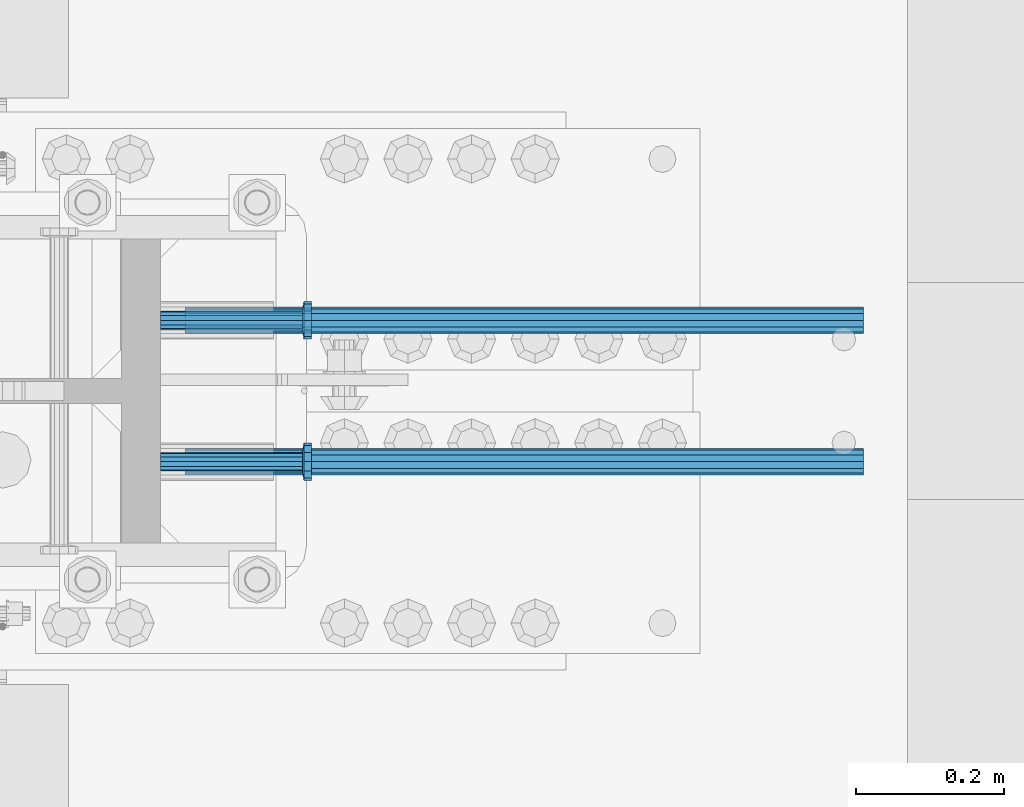
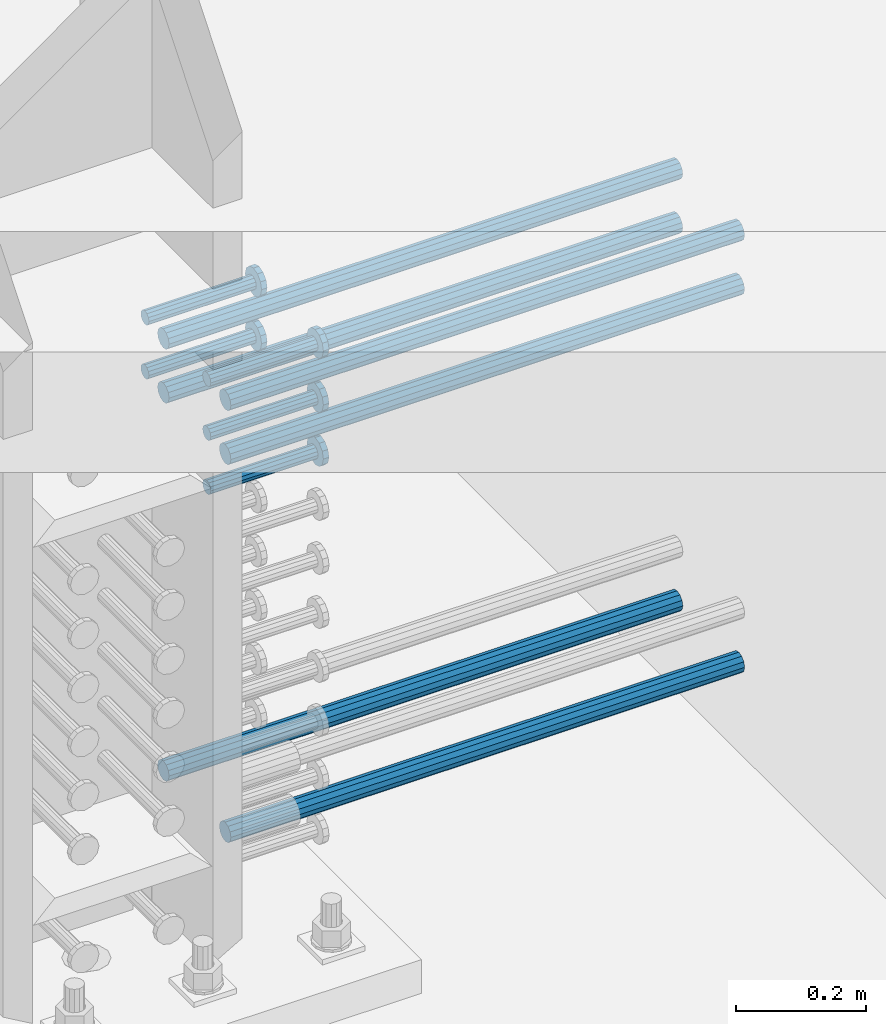
# One storey, part 1233 of 1763: 11 beams, 7 elements without a shape of their own.
"""IFC2X3 building model written with IfcOpenShell, lengths in millimetres."""

from ifc_helpers import new_model, si_unit, frame, origin_with_axes, place, context, subcontext, project, spatial, faceted_brep, material, type_object, element, aggregate, save


model = new_model("IFC2X3")

# Units and contexts
model_context = context("Model", 3, precision=1e-05, world=origin_with_axes())
body_context = subcontext(model_context, "Body", "Model", "MODEL_VIEW")
ifc_project = project(units=[si_unit("LENGTHUNIT", "METRE", prefix="MILLI"), si_unit("AREAUNIT", "SQUARE_METRE"), si_unit("VOLUMEUNIT", "CUBIC_METRE"), si_unit("MASSUNIT", "GRAM", prefix="KILO"), si_unit("TIMEUNIT", "SECOND"), si_unit("PLANEANGLEUNIT", "RADIAN"), si_unit("SOLIDANGLEUNIT", "STERADIAN"), si_unit("THERMODYNAMICTEMPERATUREUNIT", "DEGREE_CELSIUS"), si_unit("LUMINOUSINTENSITYUNIT", "LUMEN")], contexts=[model_context])

# Site, building, storey
site_placement = place(None, origin_with_axes())
site = spatial("IfcSite", under=ifc_project, at=site_placement, CompositionType="ELEMENT")
building_placement = place(site_placement, origin_with_axes())
building = spatial("IfcBuilding", under=site, at=building_placement, Name="Undefined", CompositionType="ELEMENT")
storey_placement = place(building_placement, origin_with_axes())
storey = spatial("IfcBuildingStorey", under=building, at=storey_placement, Name="Undefined", CompositionType="ELEMENT", Elevation=0.0)

# Assembly, beam
assembly_1_placement = place(storey_placement, origin_with_axes())
assembly_1 = element("IfcElementAssembly", 1, at=assembly_1_placement, inside=storey, Name="REBAR", AssemblyPlace="NOTDEFINED", PredefinedType="RIGID_FRAME")
ifc_material_1 = material(Name="STEEL/A706-GR.80")
beam_type_1 = type_object("IfcBeamType", Name="#11 REBAR", PredefinedType="NOTDEFINED")
beam_1_placement = place(assembly_1_placement, frame((-49156.9463553198, 361.949999998906, 4064.00000000003), z_axis=(0.0, 0.0, 1.0), x_axis=(1.0, 0.0, 0.0)))
beam_1 = element("IfcBeam", 2, at=beam_1_placement, type_object=beam_type_1, material=ifc_material_1, Name="REBAR", ObjectType="#11 REBAR", context=body_context, shape_type="Brep", body=[
    faceted_brep([(0.0, -17.9069999999992, 0.0), (0.0, -15.507916905568, -8.95349999999962), (914.400000001086, -15.507916905568, -8.95349999999962), (914.400000001086, -17.9069999999992, 0.0), (0.0, -8.95349999999962, -15.507916905568), (914.400000001086, -8.95349999999962, -15.507916905568), (0.0, 0.0, -17.9070000000002), (914.400000001086, 0.0, -17.9070000000002), (0.0, 8.95349999999962, -15.507916905568), (914.400000001086, 8.95349999999962, -15.507916905568), (0.0, 15.507916905568, -8.95349999999962), (914.400000001086, 15.507916905568, -8.95349999999962), (0.0, 17.9069999999992, 0.0), (914.400000001086, 17.9069999999992, 0.0), (0.0, 15.507916905568, 8.95349999999962), (914.400000001086, 15.507916905568, 8.95349999999962), (0.0, 8.95349999999962, 15.507916905568), (914.400000001086, 8.95349999999962, 15.507916905568), (0.0, 0.0, 17.9070000000002), (914.400000001086, 0.0, 17.9070000000002), (0.0, -8.95349999999962, 15.507916905568), (914.400000001086, -8.95349999999962, 15.507916905568), (0.0, -15.507916905568, 8.95349999999962), (914.400000001086, -15.507916905568, 8.95349999999962)], [[[0, 1, 2, 3]], [[1, 4, 5, 2]], [[4, 6, 7, 5]], [[6, 8, 9, 7]], [[8, 10, 11, 9]], [[10, 12, 13, 11]], [[12, 14, 15, 13]], [[14, 16, 17, 15]], [[16, 18, 19, 17]], [[18, 20, 21, 19]], [[20, 22, 23, 21]], [[22, 0, 3, 23]], [[5, 7, 9, 11, 13, 15, 17, 19, 21, 23, 3, 2]], [[22, 20, 18, 16, 14, 12, 10, 8, 6, 4, 1, 0]]]),
])
aggregate(assembly_1, [beam_1])

assembly_2_placement = place(storey_placement, origin_with_axes())
assembly_2 = element("IfcElementAssembly", 3, at=assembly_2_placement, inside=storey, Name="REBAR", AssemblyPlace="NOTDEFINED", PredefinedType="RIGID_FRAME")
beam_2_placement = place(assembly_2_placement, frame((-49156.9462866573, 552.44999999832, 4064.00000000003), z_axis=(0.0, 0.0, 1.0), x_axis=(1.0, 0.0, 0.0)))
beam_2 = element("IfcBeam", 4, at=beam_2_placement, type_object=beam_type_1, material=ifc_material_1, Name="REBAR", ObjectType="#11 REBAR", context=body_context, shape_type="Brep", body=[
    faceted_brep([(0.0, -17.9069999999992, 0.0), (0.0, -15.507916905568, -8.95349999999962), (914.400000001086, -15.507916905568, -8.95349999999962), (914.400000001086, -17.9069999999992, 0.0), (0.0, -8.95349999999962, -15.507916905568), (914.400000001086, -8.95349999999962, -15.507916905568), (0.0, 0.0, -17.9070000000002), (914.400000001086, 0.0, -17.9070000000002), (0.0, 8.95349999999962, -15.507916905568), (914.400000001086, 8.95349999999962, -15.507916905568), (0.0, 15.507916905568, -8.95349999999962), (914.400000001086, 15.507916905568, -8.95349999999962), (0.0, 17.9069999999992, 0.0), (914.400000001086, 17.9069999999992, 0.0), (0.0, 15.507916905568, 8.95349999999962), (914.400000001086, 15.507916905568, 8.95349999999962), (0.0, 8.95349999999962, 15.507916905568), (914.400000001086, 8.95349999999962, 15.507916905568), (0.0, 0.0, 17.9070000000002), (914.400000001086, 0.0, 17.9070000000002), (0.0, -8.95349999999962, 15.507916905568), (914.400000001086, -8.95349999999962, 15.507916905568), (0.0, -15.507916905568, 8.95349999999962), (914.400000001086, -15.507916905568, 8.95349999999962)], [[[0, 1, 2, 3]], [[1, 4, 5, 2]], [[4, 6, 7, 5]], [[6, 8, 9, 7]], [[8, 10, 11, 9]], [[10, 12, 13, 11]], [[12, 14, 15, 13]], [[14, 16, 17, 15]], [[16, 18, 19, 17]], [[18, 20, 21, 19]], [[20, 22, 23, 21]], [[22, 0, 3, 23]], [[5, 7, 9, 11, 13, 15, 17, 19, 21, 23, 3, 2]], [[22, 20, 18, 16, 14, 12, 10, 8, 6, 4, 1, 0]]]),
])
aggregate(assembly_2, [beam_2])

assembly_3_placement = place(storey_placement, origin_with_axes())
assembly_3 = element("IfcElementAssembly", 5, at=assembly_3_placement, inside=storey, Name="REBAR", AssemblyPlace="NOTDEFINED", PredefinedType="RIGID_FRAME")
beam_3_placement = place(assembly_3_placement, frame((-49156.9464240553, 361.949999998902, 4876.80000000009), z_axis=(0.0, 0.0, 1.0), x_axis=(1.0, 0.0, 0.0)))
beam_3 = element("IfcBeam", 6, at=beam_3_placement, type_object=beam_type_1, material=ifc_material_1, Name="REBAR", ObjectType="#11 REBAR", context=body_context, shape_type="Brep", body=[
    faceted_brep([(0.0, -17.9069999999992, 0.0), (0.0, -15.507916905568, -8.95349999999962), (914.400000001086, -15.507916905568, -8.95349999999962), (914.400000001086, -17.9069999999992, 0.0), (0.0, -8.95349999999962, -15.507916905568), (914.400000001086, -8.95349999999962, -15.507916905568), (0.0, 0.0, -17.9070000000002), (914.400000001086, 0.0, -17.9070000000002), (0.0, 8.95349999999962, -15.507916905568), (914.400000001086, 8.95349999999962, -15.507916905568), (0.0, 15.507916905568, -8.95349999999962), (914.400000001086, 15.507916905568, -8.95349999999962), (0.0, 17.9069999999992, 0.0), (914.400000001086, 17.9069999999992, 0.0), (0.0, 15.507916905568, 8.95349999999962), (914.400000001086, 15.507916905568, 8.95349999999962), (0.0, 8.95349999999962, 15.507916905568), (914.400000001086, 8.95349999999962, 15.507916905568), (0.0, 0.0, 17.9070000000002), (914.400000001086, 0.0, 17.9070000000002), (0.0, -8.95349999999962, 15.507916905568), (914.400000001086, -8.95349999999962, 15.507916905568), (0.0, -15.507916905568, 8.95349999999962), (914.400000001086, -15.507916905568, 8.95349999999962)], [[[0, 1, 2, 3]], [[1, 4, 5, 2]], [[4, 6, 7, 5]], [[6, 8, 9, 7]], [[8, 10, 11, 9]], [[10, 12, 13, 11]], [[12, 14, 15, 13]], [[14, 16, 17, 15]], [[16, 18, 19, 17]], [[18, 20, 21, 19]], [[20, 22, 23, 21]], [[22, 0, 3, 23]], [[5, 7, 9, 11, 13, 15, 17, 19, 21, 23, 3, 2]], [[22, 20, 18, 16, 14, 12, 10, 8, 6, 4, 1, 0]]]),
])
aggregate(assembly_3, [beam_3])

assembly_4_placement = place(storey_placement, origin_with_axes())
assembly_4 = element("IfcElementAssembly", 7, at=assembly_4_placement, inside=storey, Name="REBAR", AssemblyPlace="NOTDEFINED", PredefinedType="RIGID_FRAME")
beam_4_placement = place(assembly_4_placement, frame((-49156.9463553935, 552.449999998315, 4876.80000000009), z_axis=(0.0, 0.0, 1.0), x_axis=(1.0, 0.0, 0.0)))
beam_4 = element("IfcBeam", 8, at=beam_4_placement, type_object=beam_type_1, material=ifc_material_1, Name="REBAR", ObjectType="#11 REBAR", context=body_context, shape_type="Brep", body=[
    faceted_brep([(0.0, -17.9069999999992, 0.0), (0.0, -15.507916905568, -8.95349999999962), (914.400000001086, -15.507916905568, -8.95349999999962), (914.400000001086, -17.9069999999992, 0.0), (0.0, -8.95349999999962, -15.507916905568), (914.400000001086, -8.95349999999962, -15.507916905568), (0.0, 0.0, -17.9070000000002), (914.400000001086, 0.0, -17.9070000000002), (0.0, 8.95349999999962, -15.507916905568), (914.400000001086, 8.95349999999962, -15.507916905568), (0.0, 15.507916905568, -8.95349999999962), (914.400000001086, 15.507916905568, -8.95349999999962), (0.0, 17.9069999999992, 0.0), (914.400000001086, 17.9069999999992, 0.0), (0.0, 15.507916905568, 8.95349999999962), (914.400000001086, 15.507916905568, 8.95349999999962), (0.0, 8.95349999999962, 15.507916905568), (914.400000001086, 8.95349999999962, 15.507916905568), (0.0, 0.0, 17.9070000000002), (914.400000001086, 0.0, 17.9070000000002), (0.0, -8.95349999999962, 15.507916905568), (914.400000001086, -8.95349999999962, 15.507916905568), (0.0, -15.507916905568, 8.95349999999962), (914.400000001086, -15.507916905568, 8.95349999999962)], [[[0, 1, 2, 3]], [[1, 4, 5, 2]], [[4, 6, 7, 5]], [[6, 8, 9, 7]], [[8, 10, 11, 9]], [[10, 12, 13, 11]], [[12, 14, 15, 13]], [[14, 16, 17, 15]], [[16, 18, 19, 17]], [[18, 20, 21, 19]], [[20, 22, 23, 21]], [[22, 0, 3, 23]], [[5, 7, 9, 11, 13, 15, 17, 19, 21, 23, 3, 2]], [[22, 20, 18, 16, 14, 12, 10, 8, 6, 4, 1, 0]]]),
])
aggregate(assembly_4, [beam_4])

assembly_5_placement = place(storey_placement, origin_with_axes())
assembly_5 = element("IfcElementAssembly", 9, at=assembly_5_placement, inside=storey, Name="REBAR", AssemblyPlace="NOTDEFINED", PredefinedType="RIGID_FRAME")
beam_5_placement = place(assembly_5_placement, frame((-49156.9464240553, 361.949999998906, 4775.20000000009), z_axis=(0.0, 0.0, 1.0), x_axis=(1.0, 0.0, 0.0)))
beam_5 = element("IfcBeam", 10, at=beam_5_placement, type_object=beam_type_1, material=ifc_material_1, Name="REBAR", ObjectType="#11 REBAR", context=body_context, shape_type="Brep", body=[
    faceted_brep([(0.0, -17.9069999999992, 0.0), (0.0, -15.507916905568, -8.95349999999962), (914.400000001086, -15.507916905568, -8.95349999999962), (914.400000001086, -17.9069999999992, 0.0), (0.0, -8.95349999999962, -15.507916905568), (914.400000001086, -8.95349999999962, -15.507916905568), (0.0, 0.0, -17.9070000000002), (914.400000001086, 0.0, -17.9070000000002), (0.0, 8.95349999999962, -15.507916905568), (914.400000001086, 8.95349999999962, -15.507916905568), (0.0, 15.507916905568, -8.95349999999962), (914.400000001086, 15.507916905568, -8.95349999999962), (0.0, 17.9069999999992, 0.0), (914.400000001086, 17.9069999999992, 0.0), (0.0, 15.507916905568, 8.95349999999962), (914.400000001086, 15.507916905568, 8.95349999999962), (0.0, 8.95349999999962, 15.507916905568), (914.400000001086, 8.95349999999962, 15.507916905568), (0.0, 0.0, 17.9070000000002), (914.400000001086, 0.0, 17.9070000000002), (0.0, -8.95349999999962, 15.507916905568), (914.400000001086, -8.95349999999962, 15.507916905568), (0.0, -15.507916905568, 8.95349999999962), (914.400000001086, -15.507916905568, 8.95349999999962)], [[[0, 1, 2, 3]], [[1, 4, 5, 2]], [[4, 6, 7, 5]], [[6, 8, 9, 7]], [[8, 10, 11, 9]], [[10, 12, 13, 11]], [[12, 14, 15, 13]], [[14, 16, 17, 15]], [[16, 18, 19, 17]], [[18, 20, 21, 19]], [[20, 22, 23, 21]], [[22, 0, 3, 23]], [[5, 7, 9, 11, 13, 15, 17, 19, 21, 23, 3, 2]], [[22, 20, 18, 16, 14, 12, 10, 8, 6, 4, 1, 0]]]),
])
aggregate(assembly_5, [beam_5])

assembly_6_placement = place(storey_placement, origin_with_axes())
assembly_6 = element("IfcElementAssembly", 11, at=assembly_6_placement, inside=storey, Name="REBAR", AssemblyPlace="NOTDEFINED", PredefinedType="RIGID_FRAME")
beam_6_placement = place(assembly_6_placement, frame((-49156.9463553935, 552.449999998318, 4775.20000000009), z_axis=(0.0, 0.0, 1.0), x_axis=(1.0, 0.0, 0.0)))
beam_6 = element("IfcBeam", 12, at=beam_6_placement, type_object=beam_type_1, material=ifc_material_1, Name="REBAR", ObjectType="#11 REBAR", context=body_context, shape_type="Brep", body=[
    faceted_brep([(0.0, -17.9069999999992, 0.0), (0.0, -15.507916905568, -8.95349999999962), (914.400000001086, -15.507916905568, -8.95349999999962), (914.400000001086, -17.9069999999992, 0.0), (0.0, -8.95349999999962, -15.507916905568), (914.400000001086, -8.95349999999962, -15.507916905568), (0.0, 0.0, -17.9070000000002), (914.400000001086, 0.0, -17.9070000000002), (0.0, 8.95349999999962, -15.507916905568), (914.400000001086, 8.95349999999962, -15.507916905568), (0.0, 15.507916905568, -8.95349999999962), (914.400000001086, 15.507916905568, -8.95349999999962), (0.0, 17.9069999999992, 0.0), (914.400000001086, 17.9069999999992, 0.0), (0.0, 15.507916905568, 8.95349999999962), (914.400000001086, 15.507916905568, 8.95349999999962), (0.0, 8.95349999999962, 15.507916905568), (914.400000001086, 8.95349999999962, 15.507916905568), (0.0, 0.0, 17.9070000000002), (914.400000001086, 0.0, 17.9070000000002), (0.0, -8.95349999999962, 15.507916905568), (914.400000001086, -8.95349999999962, 15.507916905568), (0.0, -15.507916905568, 8.95349999999962), (914.400000001086, -15.507916905568, 8.95349999999962)], [[[0, 1, 2, 3]], [[1, 4, 5, 2]], [[4, 6, 7, 5]], [[6, 8, 9, 7]], [[8, 10, 11, 9]], [[10, 12, 13, 11]], [[12, 14, 15, 13]], [[14, 16, 17, 15]], [[16, 18, 19, 17]], [[18, 20, 21, 19]], [[20, 22, 23, 21]], [[22, 0, 3, 23]], [[5, 7, 9, 11, 13, 15, 17, 19, 21, 23, 3, 2]], [[22, 20, 18, 16, 14, 12, 10, 8, 6, 4, 1, 0]]]),
])
aggregate(assembly_6, [beam_6])

# Assembly, beams
assembly_7_placement = place(storey_placement, origin_with_axes())
assembly_7 = element("IfcElementAssembly", 13, at=assembly_7_placement, inside=storey, Name="COLUMN", AssemblyPlace="NOTDEFINED", PredefinedType="RIGID_FRAME")
ifc_material_2 = material(Name="STEEL/A108")
beam_type_2 = type_object("IfcBeamType", PredefinedType="NOTDEFINED")
beam_7_placement = place(assembly_7_placement, frame((-49189.7123897558, 361.950000000606, 4927.60000000008), z_axis=(0.0, 1.0, 0.0), x_axis=(1.0, 0.0, 0.0)))
beam_7 = element("IfcBeam", 14, at=beam_7_placement, type_object=beam_type_2, material=ifc_material_2, Name="HEADED STUD ANCHOR", context=body_context, shape_type="Brep", body=[
    faceted_brep([(0.0, -12.6999999999971, -1.81898940354586e-12), (3.63797880709171e-12, -11.0, -6.34999990463257), (191.00799999576, -11.0, -6.34999990454889), (191.007999995752, -12.6999998092651, 8.36735125631094e-11), (7.27595761418343e-12, -6.34999990463257, -11.0), (191.00799999576, -6.34999990463257, -10.9999999999163), (3.63797880709171e-12, 0.0, -12.6999998092651), (191.00799999576, 0.0, -12.6999998091815), (7.27595761418343e-12, 6.34999990463257, -11.0), (191.00799999576, 6.34999990463257, -10.9999999999163), (3.63797880709171e-12, 11.0, -6.34999990463257), (191.00799999576, 11.0, -6.34999990454889), (0.0, 12.6999999999971, -1.81898940354586e-12), (191.007999995752, 12.6999998092651, 8.36735125631094e-11), (0.0, 11.0, 6.34999990463257), (191.007999995752, 11.0, 6.34999990471624), (-3.63797880709171e-12, 6.34999990463257, 11.0), (191.007999995749, 6.34999990463257, 11.0000000000837), (-3.63797880709171e-12, 0.0, 12.6999998092651), (191.007999995749, 0.0, 12.6999998093488), (-3.63797880709171e-12, -6.34999990463257, 11.0), (191.007999995749, -6.34999990463257, 11.0000000000837), (0.0, -11.0, 6.34999990463257), (191.007999995752, -11.0, 6.34999990471624), (193.039999995715, -22.0, -12.6999998091796), (193.039999995708, -25.3999996185303, 8.54925019666553e-11), (193.039999995719, -12.6999998092651, -21.9999999999145), (193.039999995719, 0.0, -25.3999996184448), (193.039999995719, 12.6999998092651, -21.9999999999145), (193.039999995715, 22.0, -12.6999998091796), (193.039999995708, 25.3999996185303, 8.54925019666553e-11), (193.039999995704, 22.0, 12.6999998093506), (193.039999995701, 12.6999998092651, 22.0000000000855), (193.039999995697, 0.0, 25.3999996186158), (193.039999995701, -12.6999998092651, 22.0000000000855), (193.039999995704, -22.0, 12.6999998093506), (203.199999995486, -22.0, -12.6999998091742), (203.199999995482, -25.3999996185303, 9.09494701772928e-11), (203.199999995493, -12.6999998092651, -21.9999999999091), (203.199999995493, 0.0, -25.3999996184393), (203.199999995493, 12.6999998092651, -21.9999999999091), (203.199999995486, 22.0, -12.6999998091742), (203.199999995482, 25.3999996185303, 9.09494701772928e-11), (203.199999995479, 22.0, 12.6999998093561), (203.199999995475, 12.6999998092651, 22.0000000000909), (203.199999995471, 0.0, 25.3999996186212), (203.199999995475, -12.6999998092651, 22.0000000000909), (203.199999995479, -22.0, 12.6999998093561)], [[[0, 1, 2, 3]], [[1, 4, 5, 2]], [[4, 6, 7, 5]], [[6, 8, 9, 7]], [[8, 10, 11, 9]], [[10, 12, 13, 11]], [[12, 14, 15, 13]], [[14, 16, 17, 15]], [[16, 18, 19, 17]], [[18, 20, 21, 19]], [[20, 22, 23, 21]], [[22, 0, 3, 23]], [[22, 20, 18, 16, 14, 12, 10, 8, 6, 4, 1, 0]], [[3, 2, 24, 25]], [[2, 5, 26, 24]], [[5, 7, 27, 26]], [[7, 9, 28, 27]], [[9, 11, 29, 28]], [[11, 13, 30, 29]], [[13, 15, 31, 30]], [[15, 17, 32, 31]], [[17, 19, 33, 32]], [[19, 21, 34, 33]], [[21, 23, 35, 34]], [[23, 3, 25, 35]], [[25, 24, 36, 37]], [[24, 26, 38, 36]], [[26, 27, 39, 38]], [[27, 28, 40, 39]], [[28, 29, 41, 40]], [[29, 30, 42, 41]], [[30, 31, 43, 42]], [[31, 32, 44, 43]], [[32, 33, 45, 44]], [[33, 34, 46, 45]], [[34, 35, 47, 46]], [[35, 25, 37, 47]], [[38, 39, 40, 41, 42, 43, 44, 45, 46, 47, 37, 36]]]),
])
beam_8_placement = place(assembly_7_placement, frame((-49189.7123210953, 552.449999999994, 4927.60000000008), z_axis=(0.0, 1.0, 0.0), x_axis=(1.0, 0.0, 0.0)))
beam_8 = element("IfcBeam", 15, at=beam_8_placement, type_object=beam_type_2, material=ifc_material_2, Name="HEADED STUD ANCHOR", context=body_context, shape_type="Brep", body=[
    faceted_brep([(0.0, -12.6999999999971, -1.81898940354586e-12), (3.63797880709171e-12, -11.0, -6.34999990463257), (191.00799999576, -11.0, -6.34999990454889), (191.007999995752, -12.6999998092651, 8.36735125631094e-11), (7.27595761418343e-12, -6.34999990463257, -11.0), (191.00799999576, -6.34999990463257, -10.9999999999163), (3.63797880709171e-12, 0.0, -12.6999998092651), (191.00799999576, 0.0, -12.6999998091815), (7.27595761418343e-12, 6.34999990463257, -11.0), (191.00799999576, 6.34999990463257, -10.9999999999163), (3.63797880709171e-12, 11.0, -6.34999990463257), (191.00799999576, 11.0, -6.34999990454889), (0.0, 12.6999999999971, -1.81898940354586e-12), (191.007999995752, 12.6999998092651, 8.36735125631094e-11), (0.0, 11.0, 6.34999990463257), (191.007999995752, 11.0, 6.34999990471624), (-3.63797880709171e-12, 6.34999990463257, 11.0), (191.007999995749, 6.34999990463257, 11.0000000000837), (-3.63797880709171e-12, 0.0, 12.6999998092651), (191.007999995749, 0.0, 12.6999998093488), (-3.63797880709171e-12, -6.34999990463257, 11.0), (191.007999995749, -6.34999990463257, 11.0000000000837), (0.0, -11.0, 6.34999990463257), (191.007999995752, -11.0, 6.34999990471624), (193.039999995715, -22.0, -12.6999998091796), (193.039999995708, -25.3999996185303, 8.54925019666553e-11), (193.039999995719, -12.6999998092651, -21.9999999999145), (193.039999995719, 0.0, -25.3999996184448), (193.039999995719, 12.6999998092651, -21.9999999999145), (193.039999995715, 22.0, -12.6999998091796), (193.039999995708, 25.3999996185303, 8.54925019666553e-11), (193.039999995704, 22.0, 12.6999998093506), (193.039999995701, 12.6999998092651, 22.0000000000855), (193.039999995697, 0.0, 25.3999996186158), (193.039999995701, -12.6999998092651, 22.0000000000855), (193.039999995704, -22.0, 12.6999998093506), (203.199999995486, -22.0, -12.6999998091742), (203.199999995482, -25.3999996185303, 9.09494701772928e-11), (203.199999995493, -12.6999998092651, -21.9999999999091), (203.199999995493, 0.0, -25.3999996184393), (203.199999995493, 12.6999998092651, -21.9999999999091), (203.199999995486, 22.0, -12.6999998091742), (203.199999995482, 25.3999996185303, 9.09494701772928e-11), (203.199999995479, 22.0, 12.6999998093561), (203.199999995475, 12.6999998092651, 22.0000000000909), (203.199999995471, 0.0, 25.3999996186212), (203.199999995475, -12.6999998092651, 22.0000000000909), (203.199999995479, -22.0, 12.6999998093561)], [[[0, 1, 2, 3]], [[1, 4, 5, 2]], [[4, 6, 7, 5]], [[6, 8, 9, 7]], [[8, 10, 11, 9]], [[10, 12, 13, 11]], [[12, 14, 15, 13]], [[14, 16, 17, 15]], [[16, 18, 19, 17]], [[18, 20, 21, 19]], [[20, 22, 23, 21]], [[22, 0, 3, 23]], [[22, 20, 18, 16, 14, 12, 10, 8, 6, 4, 1, 0]], [[3, 2, 24, 25]], [[2, 5, 26, 24]], [[5, 7, 27, 26]], [[7, 9, 28, 27]], [[9, 11, 29, 28]], [[11, 13, 30, 29]], [[13, 15, 31, 30]], [[15, 17, 32, 31]], [[17, 19, 33, 32]], [[19, 21, 34, 33]], [[21, 23, 35, 34]], [[23, 3, 25, 35]], [[25, 24, 36, 37]], [[24, 26, 38, 36]], [[26, 27, 39, 38]], [[27, 28, 40, 39]], [[28, 29, 41, 40]], [[29, 30, 42, 41]], [[30, 31, 43, 42]], [[31, 32, 44, 43]], [[32, 33, 45, 44]], [[33, 34, 46, 45]], [[34, 35, 47, 46]], [[35, 25, 37, 47]], [[38, 39, 40, 41, 42, 43, 44, 45, 46, 47, 37, 36]]]),
])
beam_9_placement = place(assembly_7_placement, frame((-49189.7123210203, 361.950000000606, 4826.00000000007), z_axis=(0.0, 1.0, 0.0), x_axis=(1.0, 0.0, 0.0)))
beam_9 = element("IfcBeam", 16, at=beam_9_placement, type_object=beam_type_2, material=ifc_material_2, Name="HEADED STUD ANCHOR", context=body_context, shape_type="Brep", body=[
    faceted_brep([(0.0, -12.6999999999971, -1.81898940354586e-12), (3.63797880709171e-12, -11.0, -6.34999990463257), (191.00799999576, -11.0, -6.34999990454889), (191.007999995752, -12.6999998092651, 8.36735125631094e-11), (7.27595761418343e-12, -6.34999990463257, -11.0), (191.00799999576, -6.34999990463257, -10.9999999999163), (3.63797880709171e-12, 0.0, -12.6999998092651), (191.00799999576, 0.0, -12.6999998091815), (7.27595761418343e-12, 6.34999990463257, -11.0), (191.00799999576, 6.34999990463257, -10.9999999999163), (3.63797880709171e-12, 11.0, -6.34999990463257), (191.00799999576, 11.0, -6.34999990454889), (0.0, 12.6999999999971, -1.81898940354586e-12), (191.007999995752, 12.6999998092651, 8.36735125631094e-11), (0.0, 11.0, 6.34999990463257), (191.007999995752, 11.0, 6.34999990471624), (-3.63797880709171e-12, 6.34999990463257, 11.0), (191.007999995749, 6.34999990463257, 11.0000000000837), (-3.63797880709171e-12, 0.0, 12.6999998092651), (191.007999995749, 0.0, 12.6999998093488), (-3.63797880709171e-12, -6.34999990463257, 11.0), (191.007999995749, -6.34999990463257, 11.0000000000837), (0.0, -11.0, 6.34999990463257), (191.007999995752, -11.0, 6.34999990471624), (193.039999995715, -22.0, -12.6999998091796), (193.039999995708, -25.3999996185303, 8.54925019666553e-11), (193.039999995719, -12.6999998092651, -21.9999999999145), (193.039999995719, 0.0, -25.3999996184448), (193.039999995719, 12.6999998092651, -21.9999999999145), (193.039999995715, 22.0, -12.6999998091796), (193.039999995708, 25.3999996185303, 8.54925019666553e-11), (193.039999995704, 22.0, 12.6999998093506), (193.039999995701, 12.6999998092651, 22.0000000000855), (193.039999995697, 0.0, 25.3999996186158), (193.039999995701, -12.6999998092651, 22.0000000000855), (193.039999995704, -22.0, 12.6999998093506), (203.199999995486, -22.0, -12.6999998091742), (203.199999995482, -25.3999996185303, 9.09494701772928e-11), (203.199999995493, -12.6999998092651, -21.9999999999091), (203.199999995493, 0.0, -25.3999996184393), (203.199999995493, 12.6999998092651, -21.9999999999091), (203.199999995486, 22.0, -12.6999998091742), (203.199999995482, 25.3999996185303, 9.09494701772928e-11), (203.199999995479, 22.0, 12.6999998093561), (203.199999995475, 12.6999998092651, 22.0000000000909), (203.199999995471, 0.0, 25.3999996186212), (203.199999995475, -12.6999998092651, 22.0000000000909), (203.199999995479, -22.0, 12.6999998093561)], [[[0, 1, 2, 3]], [[1, 4, 5, 2]], [[4, 6, 7, 5]], [[6, 8, 9, 7]], [[8, 10, 11, 9]], [[10, 12, 13, 11]], [[12, 14, 15, 13]], [[14, 16, 17, 15]], [[16, 18, 19, 17]], [[18, 20, 21, 19]], [[20, 22, 23, 21]], [[22, 0, 3, 23]], [[22, 20, 18, 16, 14, 12, 10, 8, 6, 4, 1, 0]], [[3, 2, 24, 25]], [[2, 5, 26, 24]], [[5, 7, 27, 26]], [[7, 9, 28, 27]], [[9, 11, 29, 28]], [[11, 13, 30, 29]], [[13, 15, 31, 30]], [[15, 17, 32, 31]], [[17, 19, 33, 32]], [[19, 21, 34, 33]], [[21, 23, 35, 34]], [[23, 3, 25, 35]], [[25, 24, 36, 37]], [[24, 26, 38, 36]], [[26, 27, 39, 38]], [[27, 28, 40, 39]], [[28, 29, 41, 40]], [[29, 30, 42, 41]], [[30, 31, 43, 42]], [[31, 32, 44, 43]], [[32, 33, 45, 44]], [[33, 34, 46, 45]], [[34, 35, 47, 46]], [[35, 25, 37, 47]], [[38, 39, 40, 41, 42, 43, 44, 45, 46, 47, 37, 36]]]),
])
beam_10_placement = place(assembly_7_placement, frame((-49189.7122523598, 552.449999999994, 4826.00000000007), z_axis=(0.0, 1.0, 0.0), x_axis=(1.0, 0.0, 0.0)))
beam_10 = element("IfcBeam", 17, at=beam_10_placement, type_object=beam_type_2, material=ifc_material_2, Name="HEADED STUD ANCHOR", context=body_context, shape_type="Brep", body=[
    faceted_brep([(0.0, -12.6999999999971, -1.81898940354586e-12), (3.63797880709171e-12, -11.0, -6.34999990463257), (191.00799999576, -11.0, -6.34999990454889), (191.007999995752, -12.6999998092651, 8.36735125631094e-11), (7.27595761418343e-12, -6.34999990463257, -11.0), (191.00799999576, -6.34999990463257, -10.9999999999163), (3.63797880709171e-12, 0.0, -12.6999998092651), (191.00799999576, 0.0, -12.6999998091815), (7.27595761418343e-12, 6.34999990463257, -11.0), (191.00799999576, 6.34999990463257, -10.9999999999163), (3.63797880709171e-12, 11.0, -6.34999990463257), (191.00799999576, 11.0, -6.34999990454889), (0.0, 12.6999999999971, -1.81898940354586e-12), (191.007999995752, 12.6999998092651, 8.36735125631094e-11), (0.0, 11.0, 6.34999990463257), (191.007999995752, 11.0, 6.34999990471624), (-3.63797880709171e-12, 6.34999990463257, 11.0), (191.007999995749, 6.34999990463257, 11.0000000000837), (-3.63797880709171e-12, 0.0, 12.6999998092651), (191.007999995749, 0.0, 12.6999998093488), (-3.63797880709171e-12, -6.34999990463257, 11.0), (191.007999995749, -6.34999990463257, 11.0000000000837), (0.0, -11.0, 6.34999990463257), (191.007999995752, -11.0, 6.34999990471624), (193.039999995715, -22.0, -12.6999998091796), (193.039999995708, -25.3999996185303, 8.54925019666553e-11), (193.039999995719, -12.6999998092651, -21.9999999999145), (193.039999995719, 0.0, -25.3999996184448), (193.039999995719, 12.6999998092651, -21.9999999999145), (193.039999995715, 22.0, -12.6999998091796), (193.039999995708, 25.3999996185303, 8.54925019666553e-11), (193.039999995704, 22.0, 12.6999998093506), (193.039999995701, 12.6999998092651, 22.0000000000855), (193.039999995697, 0.0, 25.3999996186158), (193.039999995701, -12.6999998092651, 22.0000000000855), (193.039999995704, -22.0, 12.6999998093506), (203.199999995486, -22.0, -12.6999998091742), (203.199999995482, -25.3999996185303, 9.09494701772928e-11), (203.199999995493, -12.6999998092651, -21.9999999999091), (203.199999995493, 0.0, -25.3999996184393), (203.199999995493, 12.6999998092651, -21.9999999999091), (203.199999995486, 22.0, -12.6999998091742), (203.199999995482, 25.3999996185303, 9.09494701772928e-11), (203.199999995479, 22.0, 12.6999998093561), (203.199999995475, 12.6999998092651, 22.0000000000909), (203.199999995471, 0.0, 25.3999996186212), (203.199999995475, -12.6999998092651, 22.0000000000909), (203.199999995479, -22.0, 12.6999998093561)], [[[0, 1, 2, 3]], [[1, 4, 5, 2]], [[4, 6, 7, 5]], [[6, 8, 9, 7]], [[8, 10, 11, 9]], [[10, 12, 13, 11]], [[12, 14, 15, 13]], [[14, 16, 17, 15]], [[16, 18, 19, 17]], [[18, 20, 21, 19]], [[20, 22, 23, 21]], [[22, 0, 3, 23]], [[22, 20, 18, 16, 14, 12, 10, 8, 6, 4, 1, 0]], [[3, 2, 24, 25]], [[2, 5, 26, 24]], [[5, 7, 27, 26]], [[7, 9, 28, 27]], [[9, 11, 29, 28]], [[11, 13, 30, 29]], [[13, 15, 31, 30]], [[15, 17, 32, 31]], [[17, 19, 33, 32]], [[19, 21, 34, 33]], [[21, 23, 35, 34]], [[23, 3, 25, 35]], [[25, 24, 36, 37]], [[24, 26, 38, 36]], [[26, 27, 39, 38]], [[27, 28, 40, 39]], [[28, 29, 41, 40]], [[29, 30, 42, 41]], [[30, 31, 43, 42]], [[31, 32, 44, 43]], [[32, 33, 45, 44]], [[33, 34, 46, 45]], [[34, 35, 47, 46]], [[35, 25, 37, 47]], [[38, 39, 40, 41, 42, 43, 44, 45, 46, 47, 37, 36]]]),
])
beam_11_placement = place(assembly_7_placement, frame((-49189.7123210203, 361.950000000606, 4724.40000000007), z_axis=(0.0, 1.0, 0.0), x_axis=(1.0, 0.0, 0.0)))
beam_11 = element("IfcBeam", 18, at=beam_11_placement, type_object=beam_type_2, material=ifc_material_2, Name="HEADED STUD ANCHOR", context=body_context, shape_type="Brep", body=[
    faceted_brep([(0.0, -12.6999999999971, -1.81898940354586e-12), (3.63797880709171e-12, -11.0, -6.34999990463257), (191.00799999576, -11.0, -6.34999990454889), (191.007999995752, -12.6999998092651, 8.36735125631094e-11), (7.27595761418343e-12, -6.34999990463257, -11.0), (191.00799999576, -6.34999990463257, -10.9999999999163), (3.63797880709171e-12, 0.0, -12.6999998092651), (191.00799999576, 0.0, -12.6999998091815), (7.27595761418343e-12, 6.34999990463257, -11.0), (191.00799999576, 6.34999990463257, -10.9999999999163), (3.63797880709171e-12, 11.0, -6.34999990463257), (191.00799999576, 11.0, -6.34999990454889), (0.0, 12.6999999999971, -1.81898940354586e-12), (191.007999995752, 12.6999998092651, 8.36735125631094e-11), (0.0, 11.0, 6.34999990463257), (191.007999995752, 11.0, 6.34999990471624), (-3.63797880709171e-12, 6.34999990463257, 11.0), (191.007999995749, 6.34999990463257, 11.0000000000837), (-3.63797880709171e-12, 0.0, 12.6999998092651), (191.007999995749, 0.0, 12.6999998093488), (-3.63797880709171e-12, -6.34999990463257, 11.0), (191.007999995749, -6.34999990463257, 11.0000000000837), (0.0, -11.0, 6.34999990463257), (191.007999995752, -11.0, 6.34999990471624), (193.039999995715, -22.0, -12.6999998091796), (193.039999995708, -25.3999996185303, 8.54925019666553e-11), (193.039999995719, -12.6999998092651, -21.9999999999145), (193.039999995719, 0.0, -25.3999996184448), (193.039999995719, 12.6999998092651, -21.9999999999145), (193.039999995715, 22.0, -12.6999998091796), (193.039999995708, 25.3999996185303, 8.54925019666553e-11), (193.039999995704, 22.0, 12.6999998093506), (193.039999995701, 12.6999998092651, 22.0000000000855), (193.039999995697, 0.0, 25.3999996186158), (193.039999995701, -12.6999998092651, 22.0000000000855), (193.039999995704, -22.0, 12.6999998093506), (203.199999995486, -22.0, -12.6999998091742), (203.199999995482, -25.3999996185303, 9.09494701772928e-11), (203.199999995493, -12.6999998092651, -21.9999999999091), (203.199999995493, 0.0, -25.3999996184393), (203.199999995493, 12.6999998092651, -21.9999999999091), (203.199999995486, 22.0, -12.6999998091742), (203.199999995482, 25.3999996185303, 9.09494701772928e-11), (203.199999995479, 22.0, 12.6999998093561), (203.199999995475, 12.6999998092651, 22.0000000000909), (203.199999995471, 0.0, 25.3999996186212), (203.199999995475, -12.6999998092651, 22.0000000000909), (203.199999995479, -22.0, 12.6999998093561)], [[[0, 1, 2, 3]], [[1, 4, 5, 2]], [[4, 6, 7, 5]], [[6, 8, 9, 7]], [[8, 10, 11, 9]], [[10, 12, 13, 11]], [[12, 14, 15, 13]], [[14, 16, 17, 15]], [[16, 18, 19, 17]], [[18, 20, 21, 19]], [[20, 22, 23, 21]], [[22, 0, 3, 23]], [[22, 20, 18, 16, 14, 12, 10, 8, 6, 4, 1, 0]], [[3, 2, 24, 25]], [[2, 5, 26, 24]], [[5, 7, 27, 26]], [[7, 9, 28, 27]], [[9, 11, 29, 28]], [[11, 13, 30, 29]], [[13, 15, 31, 30]], [[15, 17, 32, 31]], [[17, 19, 33, 32]], [[19, 21, 34, 33]], [[21, 23, 35, 34]], [[23, 3, 25, 35]], [[25, 24, 36, 37]], [[24, 26, 38, 36]], [[26, 27, 39, 38]], [[27, 28, 40, 39]], [[28, 29, 41, 40]], [[29, 30, 42, 41]], [[30, 31, 43, 42]], [[31, 32, 44, 43]], [[32, 33, 45, 44]], [[33, 34, 46, 45]], [[34, 35, 47, 46]], [[35, 25, 37, 47]], [[38, 39, 40, 41, 42, 43, 44, 45, 46, 47, 37, 36]]]),
])
aggregate(assembly_7, [beam_7, beam_8, beam_9, beam_10, beam_11])

save(model, "model.ifc")
